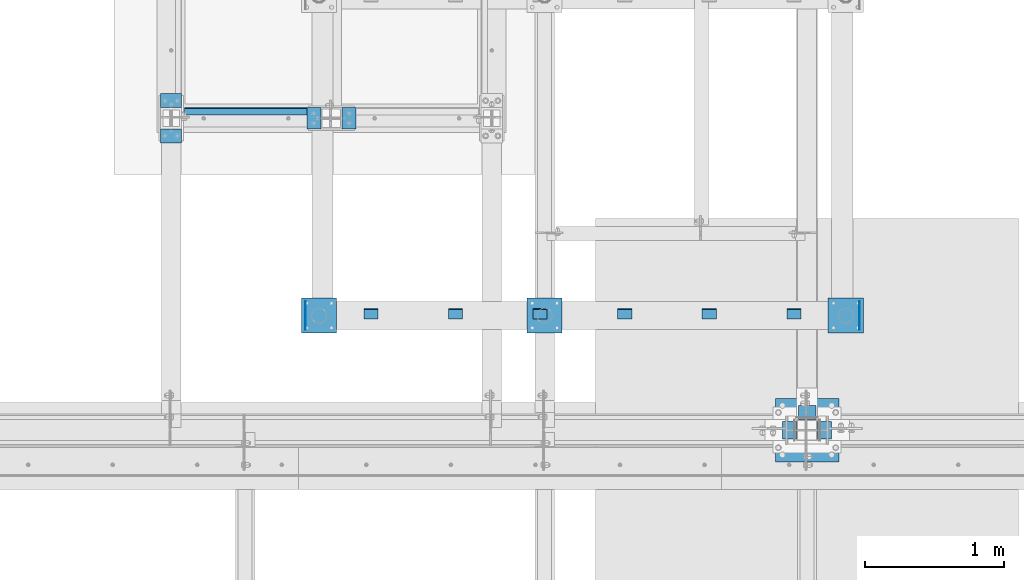
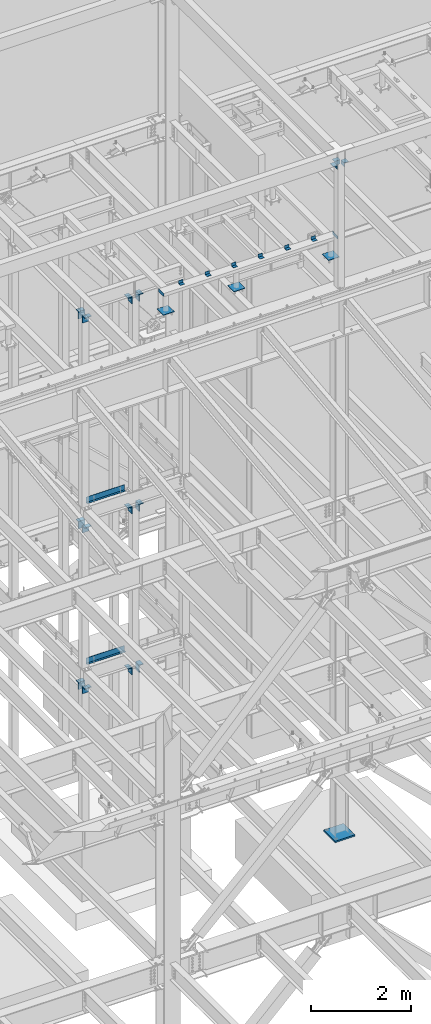
# One storey, part 891 of 1179: 29 beams, 11 elements without a shape of their own.
"""IFC2X3 building model written with IfcOpenShell, lengths in millimetres."""

from ifc_helpers import new_model, si_unit, frame, origin_with_axes, place, context, subcontext, project, spatial, faceted_brep, material, type_object, element, aggregate, save


model = new_model("IFC2X3")

# Units and contexts
model_context = context("Model", 3, precision=1e-05, world=origin_with_axes())
body_context = subcontext(model_context, "Body", "Model", "MODEL_VIEW")
ifc_project = project(units=[si_unit("LENGTHUNIT", "METRE", prefix="MILLI"), si_unit("AREAUNIT", "SQUARE_METRE"), si_unit("VOLUMEUNIT", "CUBIC_METRE"), si_unit("MASSUNIT", "GRAM", prefix="KILO"), si_unit("TIMEUNIT", "SECOND"), si_unit("PLANEANGLEUNIT", "RADIAN"), si_unit("SOLIDANGLEUNIT", "STERADIAN"), si_unit("THERMODYNAMICTEMPERATUREUNIT", "DEGREE_CELSIUS"), si_unit("LUMINOUSINTENSITYUNIT", "LUMEN")], contexts=[model_context])

# Site, building, storey
site_placement = place(None, origin_with_axes())
site = spatial("IfcSite", under=ifc_project, at=site_placement, CompositionType="ELEMENT")
building_placement = place(site_placement, origin_with_axes())
building = spatial("IfcBuilding", under=site, at=building_placement, Name="Undefined", CompositionType="ELEMENT")
storey_placement = place(building_placement, origin_with_axes())
storey = spatial("IfcBuildingStorey", under=building, at=storey_placement, Name="Undefined", CompositionType="ELEMENT", Elevation=0.0)

# Assembly, beams
assembly_1_placement = place(storey_placement, origin_with_axes())
assembly_1 = element("IfcElementAssembly", 1, at=assembly_1_placement, inside=storey, Name="FRAME", AssemblyPlace="NOTDEFINED", PredefinedType="RIGID_FRAME")
ifc_material_1 = material(Name="STEEL/A36")
beam_type_1 = type_object("IfcBeamType", Name="L3X3X1/4", PredefinedType="NOTDEFINED")
beam_1_placement = place(assembly_1_placement, frame((16313.15, 35229.8, 13798.55), z_axis=(0.0, 0.0, 1.0), x_axis=(1.0, 0.0, 0.0)))
beam_1 = element("IfcBeam", 2, at=beam_1_placement, type_object=beam_type_1, material=ifc_material_1, Name="ANGLE", ObjectType="L3X3X1/4", context=body_context, shape_type="Brep", body=[
    faceted_brep([(0.0, 38.0999999999985, -38.0999999999999), (0.0, 38.0999999999985, 38.0999999999999), (101.600000000035, 38.0999999999985, 38.099999999994), (101.599999999962, 38.0999999999985, -38.1000000000058), (0.0, 31.75, 38.1000000000004), (101.600000000035, 31.75, 38.099999999994), (0.0, 31.75, -31.75), (101.599999999969, 31.75, -31.7500000000064), (0.0, -38.0999999999985, -31.75), (101.599999999969, -38.0999999999985, -31.7500000000064), (0.0, -38.0999999999985, -38.0999999999999), (101.599999999962, -38.0999999999985, -38.1000000000058)], [[[0, 1, 2, 3]], [[1, 4, 5, 2]], [[4, 6, 7, 5]], [[6, 8, 9, 7]], [[8, 10, 11, 9]], [[10, 0, 3, 11]], [[5, 7, 9, 11, 3, 2]], [[10, 8, 6, 4, 1, 0]]]),
])
beam_2_placement = place(assembly_1_placement, frame((15703.55, 35229.8, 13798.55), z_axis=(0.0, 0.0, 1.0), x_axis=(1.0, 0.0, 0.0)))
beam_2 = element("IfcBeam", 3, at=beam_2_placement, type_object=beam_type_1, material=ifc_material_1, Name="ANGLE", ObjectType="L3X3X1/4", context=body_context, shape_type="Brep", body=[
    faceted_brep([(0.0, 38.0999999999985, -38.0999999999999), (0.0, 38.0999999999985, 38.0999999999999), (101.600000000035, 38.0999999999985, 38.099999999994), (101.599999999962, 38.0999999999985, -38.1000000000058), (0.0, 31.75, 38.1000000000004), (101.600000000035, 31.75, 38.099999999994), (0.0, 31.75, -31.75), (101.599999999969, 31.75, -31.7500000000064), (0.0, -38.0999999999985, -31.75), (101.599999999969, -38.0999999999985, -31.7500000000064), (0.0, -38.0999999999985, -38.0999999999999), (101.599999999962, -38.0999999999985, -38.1000000000058)], [[[0, 1, 2, 3]], [[1, 4, 5, 2]], [[4, 6, 7, 5]], [[6, 8, 9, 7]], [[8, 10, 11, 9]], [[10, 0, 3, 11]], [[5, 7, 9, 11, 3, 2]], [[10, 8, 6, 4, 1, 0]]]),
])
beam_3_placement = place(assembly_1_placement, frame((15093.95, 35229.8, 13798.55), z_axis=(0.0, 0.0, 1.0), x_axis=(1.0, 0.0, 0.0)))
beam_3 = element("IfcBeam", 4, at=beam_3_placement, type_object=beam_type_1, material=ifc_material_1, Name="ANGLE", ObjectType="L3X3X1/4", context=body_context, shape_type="Brep", body=[
    faceted_brep([(0.0, 38.0999999999985, -38.0999999999999), (0.0, 38.0999999999985, 38.0999999999999), (101.600000000035, 38.0999999999985, 38.099999999994), (101.599999999962, 38.0999999999985, -38.1000000000058), (0.0, 31.75, 38.1000000000004), (101.600000000035, 31.75, 38.099999999994), (0.0, 31.75, -31.75), (101.599999999969, 31.75, -31.7500000000064), (0.0, -38.0999999999985, -31.75), (101.599999999969, -38.0999999999985, -31.7500000000064), (0.0, -38.0999999999985, -38.0999999999999), (101.599999999962, -38.0999999999985, -38.1000000000058)], [[[0, 1, 2, 3]], [[1, 4, 5, 2]], [[4, 6, 7, 5]], [[6, 8, 9, 7]], [[8, 10, 11, 9]], [[10, 0, 3, 11]], [[5, 7, 9, 11, 3, 2]], [[10, 8, 6, 4, 1, 0]]]),
])
beam_4_placement = place(assembly_1_placement, frame((14484.35, 35229.8, 13798.55), z_axis=(0.0, 0.0, 1.0), x_axis=(1.0, 0.0, 0.0)))
beam_4 = element("IfcBeam", 5, at=beam_4_placement, type_object=beam_type_1, material=ifc_material_1, Name="ANGLE", ObjectType="L3X3X1/4", context=body_context, shape_type="Brep", body=[
    faceted_brep([(0.0, 38.0999999999985, -38.0999999999999), (0.0, 38.0999999999985, 38.0999999999999), (101.600000000035, 38.0999999999985, 38.099999999994), (101.599999999962, 38.0999999999985, -38.1000000000058), (0.0, 31.75, 38.1000000000004), (101.600000000035, 31.75, 38.099999999994), (0.0, 31.75, -31.75), (101.599999999969, 31.75, -31.7500000000064), (0.0, -38.0999999999985, -31.75), (101.599999999969, -38.0999999999985, -31.7500000000064), (0.0, -38.0999999999985, -38.0999999999999), (101.599999999962, -38.0999999999985, -38.1000000000058)], [[[0, 1, 2, 3]], [[1, 4, 5, 2]], [[4, 6, 7, 5]], [[6, 8, 9, 7]], [[8, 10, 11, 9]], [[10, 0, 3, 11]], [[5, 7, 9, 11, 3, 2]], [[10, 8, 6, 4, 1, 0]]]),
])
beam_5_placement = place(assembly_1_placement, frame((13874.75, 35229.8, 13798.55), z_axis=(0.0, 0.0, 1.0), x_axis=(1.0, 0.0, 0.0)))
beam_5 = element("IfcBeam", 6, at=beam_5_placement, type_object=beam_type_1, material=ifc_material_1, Name="ANGLE", ObjectType="L3X3X1/4", context=body_context, shape_type="Brep", body=[
    faceted_brep([(0.0, 38.0999999999985, -38.0999999999999), (0.0, 38.0999999999985, 38.0999999999999), (101.600000000035, 38.0999999999985, 38.099999999994), (101.599999999962, 38.0999999999985, -38.1000000000058), (0.0, 31.75, 38.1000000000004), (101.600000000035, 31.75, 38.099999999994), (0.0, 31.75, -31.75), (101.599999999969, 31.75, -31.7500000000064), (0.0, -38.0999999999985, -31.75), (101.599999999969, -38.0999999999985, -31.7500000000064), (0.0, -38.0999999999985, -38.0999999999999), (101.599999999962, -38.0999999999985, -38.1000000000058)], [[[0, 1, 2, 3]], [[1, 4, 5, 2]], [[4, 6, 7, 5]], [[6, 8, 9, 7]], [[8, 10, 11, 9]], [[10, 0, 3, 11]], [[5, 7, 9, 11, 3, 2]], [[10, 8, 6, 4, 1, 0]]]),
])
beam_6_placement = place(assembly_1_placement, frame((13265.15, 35229.8, 13798.55), z_axis=(0.0, 0.0, 1.0), x_axis=(1.0, 0.0, 0.0)))
beam_6 = element("IfcBeam", 7, at=beam_6_placement, type_object=beam_type_1, material=ifc_material_1, Name="ANGLE", ObjectType="L3X3X1/4", context=body_context, shape_type="Brep", body=[
    faceted_brep([(0.0, 38.0999999999985, -38.0999999999999), (0.0, 38.0999999999985, 38.0999999999999), (101.600000000035, 38.0999999999985, 38.099999999994), (101.599999999962, 38.0999999999985, -38.1000000000058), (0.0, 31.75, 38.1000000000004), (101.600000000035, 31.75, 38.099999999994), (0.0, 31.75, -31.75), (101.599999999969, 31.75, -31.7500000000064), (0.0, -38.0999999999985, -31.75), (101.599999999969, -38.0999999999985, -31.7500000000064), (0.0, -38.0999999999985, -38.0999999999999), (101.599999999962, -38.0999999999985, -38.1000000000058)], [[[0, 1, 2, 3]], [[1, 4, 5, 2]], [[4, 6, 7, 5]], [[6, 8, 9, 7]], [[8, 10, 11, 9]], [[10, 0, 3, 11]], [[5, 7, 9, 11, 3, 2]], [[10, 8, 6, 4, 1, 0]]]),
])
beam_type_2 = type_object("IfcBeamType", PredefinedType="NOTDEFINED")
beam_7_placement = place(assembly_1_placement, frame((16837.819, 35318.7, 13722.35), z_axis=(0.0, 0.0, 1.0), x_axis=(0.0, -1.0, 0.0)))
beam_7 = element("IfcBeam", 8, at=beam_7_placement, type_object=beam_type_2, material=ifc_material_1, Name="PLATE", context=body_context, shape_type="Brep", body=[
    faceted_brep([(0.0, 2.38149999999951, -38.0999999999985), (0.0, 2.38149999999951, 38.0999999999985), (203.199999999997, 2.38150000000314, 38.1000000000004), (203.199999999997, 2.38150000000314, -38.1000000000004), (0.0, -2.38149999999951, 38.0999999999985), (203.199999999997, -2.38150000000314, 38.1000000000004), (0.0, -2.38149999999951, -38.0999999999985), (203.199999999997, -2.38150000000314, -38.1000000000004)], [[[0, 1, 2, 3]], [[1, 4, 5, 2]], [[4, 6, 7, 5]], [[6, 0, 3, 7]], [[5, 7, 3, 2]], [[6, 4, 1, 0]]]),
])
beam_8_placement = place(assembly_1_placement, frame((12842.081, 35318.7, 13722.35), z_axis=(0.0, 0.0, -1.0), x_axis=(0.0, -1.0, 0.0)))
beam_8 = element("IfcBeam", 9, at=beam_8_placement, type_object=beam_type_2, material=ifc_material_1, Name="PLATE", context=body_context, shape_type="Brep", body=[
    faceted_brep([(0.0, 2.38149999999951, -38.0999999999985), (0.0, 2.38149999999951, 38.0999999999985), (203.199999999997, 2.38150000000314, 38.1000000000004), (203.199999999997, 2.38150000000314, -38.1000000000004), (0.0, -2.38149999999951, 38.0999999999985), (203.199999999997, -2.38150000000314, 38.1000000000004), (0.0, -2.38149999999951, -38.0999999999985), (203.199999999997, -2.38150000000314, -38.1000000000004)], [[[0, 1, 2, 3]], [[1, 4, 5, 2]], [[4, 6, 7, 5]], [[6, 0, 3, 7]], [[5, 7, 3, 2]], [[6, 4, 1, 0]]]),
])

# Assembly, beam
assembly_2_placement = place(storey_placement, origin_with_axes())
assembly_2 = element("IfcElementAssembly", 10, at=assembly_2_placement, inside=storey, Name="BEAM", AssemblyPlace="NOTDEFINED", PredefinedType="RIGID_FRAME")
beam_type_3 = type_object("IfcBeamType", PredefinedType="NOTDEFINED")
beam_9_placement = place(assembly_2_placement, frame((12414.24988175, 36712.5249960929, 8147.05000610352), z_axis=(1.0, 0.0, 0.0), x_axis=(0.0, 0.0, -1.0)))
beam_9 = element("IfcBeam", 11, at=beam_9_placement, type_object=beam_type_3, material=ifc_material_1, Name="BENT_PLATE", context=body_context, shape_type="Brep", body=[
    faceted_brep([(0.0, -3.17500000000291, -444.5), (0.0, -3.17500000000291, 444.5), (0.0, 3.17500000000291, 444.5), (0.0, 3.17500000000291, -444.5), (133.350006103513, 3.17500000000291, 444.5), (133.350006103513, 3.17500000000291, -444.5), (127.000006103513, -3.17500000000291, -444.5), (127.000006103513, -3.17500000000291, 444.5), (133.350006103513, -47.6249984741225, 444.5), (133.350006103513, -47.6249984741225, -444.5), (127.000006103513, -47.6249984741225, 444.5), (127.000006103513, -47.6249984741225, -444.5)], [[[0, 1, 2, 3]], [[3, 2, 4, 5]], [[1, 0, 6, 7]], [[5, 4, 8, 9]], [[4, 2, 1, 7, 10, 8]], [[7, 6, 11, 10]], [[6, 0, 3, 5, 9, 11]], [[10, 11, 9, 8]]]),
])
aggregate(assembly_2, [beam_9])

assembly_3_placement = place(storey_placement, origin_with_axes())
assembly_3 = element("IfcElementAssembly", 12, at=assembly_3_placement, inside=storey, Name="BEAM", AssemblyPlace="NOTDEFINED", PredefinedType="RIGID_FRAME")
beam_10_placement = place(assembly_3_placement, frame((12414.2500030518, 36712.5249984741, 4235.45000610352), z_axis=(1.0, 0.0, 0.0), x_axis=(0.0, 0.0, -1.0)))
beam_10 = element("IfcBeam", 13, at=beam_10_placement, type_object=beam_type_3, material=ifc_material_1, Name="BENT_PLATE", context=body_context, shape_type="Brep", body=[
    faceted_brep([(0.0, -3.17500000000291, -444.5), (0.0, -3.17500000000291, 444.5), (0.0, 3.17500000000291, 444.5), (0.0, 3.17500000000291, -444.5), (133.350006103513, 3.17500000000291, 444.5), (133.350006103513, 3.17500000000291, -444.5), (127.000006103513, -3.17500000000291, -444.5), (127.000006103513, -3.17500000000291, 444.5), (133.350006103513, -47.6249984741225, 444.5), (133.350006103513, -47.6249984741225, -444.5), (127.000006103513, -47.6249984741225, 444.5), (127.000006103513, -47.6249984741225, -444.5)], [[[0, 1, 2, 3]], [[3, 2, 4, 5]], [[1, 0, 6, 7]], [[5, 4, 8, 9]], [[4, 2, 1, 7, 10, 8]], [[7, 6, 11, 10]], [[6, 0, 3, 5, 9, 11]], [[10, 11, 9, 8]]]),
])
aggregate(assembly_3, [beam_10])

# Assembly, beams
assembly_4_placement = place(storey_placement, origin_with_axes())
assembly_4 = element("IfcElementAssembly", 14, at=assembly_4_placement, inside=storey, Name="COLUMN", AssemblyPlace="NOTDEFINED", PredefinedType="RIGID_FRAME")
beam_type_4 = type_object("IfcBeamType", Name="L4X4X3/8", PredefinedType="NOTDEFINED")
beam_11_placement = place(assembly_4_placement, frame((16522.7, 34518.6, 16071.85), z_axis=(0.0, 1.0, 0.0), x_axis=(-1.0, 0.0, 0.0)))
beam_11 = element("IfcBeam", 15, at=beam_11_placement, type_object=beam_type_4, material=ifc_material_1, Name="ANGLE", ObjectType="L4X4X3/8", context=body_context, shape_type="Brep", body=[
    faceted_brep([(1.90993887372315e-11, 50.8000000000002, -50.8000000000002), (1.90993887372315e-11, 50.8000000000002, 50.8000000000002), (126.999999999993, 50.8000000000002, 50.7999999999993), (126.999999999993, 50.8000000000002, -50.7999999999993), (0.0, 41.2750000000015, 50.8000000000029), (126.999999999993, 41.2749999999996, 50.7999999999993), (0.0, 41.2750000000015, -41.2750000000015), (126.999999999993, 41.2749999999996, -41.2749999999996), (0.0, -50.7999999999993, -41.2750000000015), (126.999999999993, -50.8000000000002, -41.2749999999996), (-1.81898940354586e-11, -50.7999999999997, -50.8000000000002), (126.999999999993, -50.8000000000002, -50.7999999999993)], [[[0, 1, 2, 3]], [[1, 4, 5, 2]], [[4, 6, 7, 5]], [[6, 8, 9, 7]], [[8, 10, 11, 9]], [[10, 0, 3, 11]], [[5, 7, 9, 11, 3, 2]], [[10, 8, 6, 4, 1, 0]]]),
])
beam_12_placement = place(assembly_4_placement, frame((16332.2, 34328.1, 16071.85), z_axis=(0.0, 0.0, -1.0), x_axis=(0.0, 1.0, 0.0)))
beam_12 = element("IfcBeam", 16, at=beam_12_placement, type_object=beam_type_4, material=ifc_material_1, Name="ANGLE", ObjectType="L4X4X3/8", context=body_context, shape_type="Brep", body=[
    faceted_brep([(1.90993887372315e-11, 50.8000000000002, -50.8000000000002), (1.90993887372315e-11, 50.8000000000002, 50.8000000000002), (126.999999999993, 50.8000000000002, 50.7999999999993), (126.999999999993, 50.8000000000002, -50.7999999999993), (0.0, 41.2750000000015, 50.8000000000029), (126.999999999993, 41.2749999999996, 50.7999999999993), (0.0, 41.2750000000015, -41.2750000000015), (126.999999999993, 41.2749999999996, -41.2749999999996), (0.0, -50.7999999999993, -41.2750000000015), (126.999999999993, -50.8000000000002, -41.2749999999996), (-1.81898940354586e-11, -50.7999999999997, -50.8000000000002), (126.999999999993, -50.8000000000002, -50.7999999999993)], [[[0, 1, 2, 3]], [[1, 4, 5, 2]], [[4, 6, 7, 5]], [[6, 8, 9, 7]], [[8, 10, 11, 9]], [[10, 0, 3, 11]], [[5, 7, 9, 11, 3, 2]], [[10, 8, 6, 4, 1, 0]]]),
])
beam_13_placement = place(assembly_4_placement, frame((16586.2, 34328.1, 16071.85), z_axis=(1.0, 0.0, 0.0), x_axis=(0.0, 1.0, 0.0)))
beam_13 = element("IfcBeam", 17, at=beam_13_placement, type_object=beam_type_4, material=ifc_material_1, Name="ANGLE", ObjectType="L4X4X3/8", context=body_context, shape_type="Brep", body=[
    faceted_brep([(1.90993887372315e-11, 50.8000000000002, -50.8000000000002), (1.90993887372315e-11, 50.8000000000002, 50.8000000000002), (126.999999999993, 50.8000000000002, 50.7999999999993), (126.999999999993, 50.8000000000002, -50.7999999999993), (0.0, 41.2750000000015, 50.8000000000029), (126.999999999993, 41.2749999999996, 50.7999999999993), (0.0, 41.2750000000015, -41.2750000000015), (126.999999999993, 41.2749999999996, -41.2749999999996), (0.0, -50.7999999999993, -41.2750000000015), (126.999999999993, -50.8000000000002, -41.2749999999996), (-1.81898940354586e-11, -50.7999999999997, -50.8000000000002), (126.999999999993, -50.8000000000002, -50.7999999999993)], [[[0, 1, 2, 3]], [[1, 4, 5, 2]], [[4, 6, 7, 5]], [[6, 8, 9, 7]], [[8, 10, 11, 9]], [[10, 0, 3, 11]], [[5, 7, 9, 11, 3, 2]], [[10, 8, 6, 4, 1, 0]]]),
])
aggregate(assembly_4, [beam_11, beam_12, beam_13])

assembly_5_placement = place(storey_placement, origin_with_axes())
assembly_5 = element("IfcElementAssembly", 18, at=assembly_5_placement, inside=storey, Name="COLUMN", AssemblyPlace="NOTDEFINED", PredefinedType="RIGID_FRAME")
beam_type_5 = type_object("IfcBeamType", PredefinedType="NOTDEFINED")
beam_14_placement = place(assembly_5_placement, frame((12852.4000014685, 36639.5000000217, 12763.5), z_axis=(0.0, 1.0, 0.0), x_axis=(1.0, 0.0, 0.0)))
beam_14 = element("IfcBeam", 19, at=beam_14_placement, type_object=beam_type_5, material=ifc_material_1, Name="BENT_PLATE", context=body_context, shape_type="Brep", body=[
    faceted_brep([(7.27595761418343e-12, -6.35000000000036, -76.1999999999971), (0.0, -6.35000000000036, 76.2000000000044), (0.0, 6.35000000000036, 76.2000000000044), (-7.27595761418343e-12, 6.35000000000036, -76.1999999999971), (88.8999984741222, 6.34999999999991, 76.2000000000007), (88.8999984741222, 6.34999999999991, -76.2000000000007), (101.599998474123, -6.34999999999991, -76.2000000000007), (101.599998474123, -6.34999999999991, 76.2000000000007), (88.8999984741222, 171.450003051757, 76.2000000000007), (88.8999984741222, 171.450003051757, -76.2000000000007), (101.599998474123, 171.450003051757, 76.2000000000007), (101.599998474123, 171.450003051757, -76.2000000000007)], [[[0, 1, 2, 3]], [[3, 2, 4, 5]], [[1, 0, 6, 7]], [[5, 4, 8, 9]], [[4, 2, 1, 7, 10, 8]], [[7, 6, 11, 10]], [[6, 0, 3, 5, 9, 11]], [[10, 11, 9, 8]]]),
])
beam_15_placement = place(assembly_5_placement, frame((13207.9999984167, 36639.500000021, 12763.5), z_axis=(0.0, 1.0, 0.0), x_axis=(-1.0, 0.0, 0.0)))
beam_15 = element("IfcBeam", 20, at=beam_15_placement, type_object=beam_type_5, material=ifc_material_1, Name="BENT_PLATE", context=body_context, shape_type="Brep", body=[
    faceted_brep([(7.27595761418343e-12, -6.35000000000036, -76.1999999999971), (0.0, -6.35000000000036, 76.2000000000044), (0.0, 6.35000000000036, 76.2000000000044), (-7.27595761418343e-12, 6.35000000000036, -76.1999999999971), (101.599998474123, 6.34999999999991, 76.2000000000007), (101.599998474123, 6.34999999999991, -76.2000000000007), (88.8999984741222, -6.34999999999991, -76.2000000000007), (88.8999984741222, -6.34999999999991, 76.2000000000007), (101.599998474123, -171.450003051757, 76.2000000000007), (101.599998474123, -171.450003051757, -76.2000000000007), (88.8999984741222, -171.450003051757, 76.2000000000007), (88.8999984741222, -171.450003051757, -76.2000000000007)], [[[0, 1, 2, 3]], [[3, 2, 4, 5]], [[1, 0, 6, 7]], [[5, 4, 8, 9]], [[4, 2, 1, 7, 10, 8]], [[7, 6, 11, 10]], [[6, 0, 3, 5, 9, 11]], [[10, 11, 9, 8]]]),
])
aggregate(assembly_5, [beam_14, beam_15])

assembly_6_placement = place(storey_placement, origin_with_axes())
assembly_6 = element("IfcElementAssembly", 21, at=assembly_6_placement, inside=storey, Name="COLUMN", AssemblyPlace="NOTDEFINED", PredefinedType="RIGID_FRAME")
beam_16_placement = place(assembly_6_placement, frame((11874.5, 36817.2999984741, 12709.525), z_axis=(1.0, 0.0, 0.0), x_axis=(0.0, -1.0, 0.0)))
beam_16 = element("IfcBeam", 22, at=beam_16_placement, type_object=beam_type_5, material=ifc_material_1, Name="BENT_PLATE", context=body_context, shape_type="Brep", body=[
    faceted_brep([(7.27595761418343e-12, -6.35000000000036, -76.1999999999971), (0.0, -6.35000000000036, 76.2000000000044), (0.0, 6.35000000000036, 76.2000000000044), (-7.27595761418343e-12, 6.35000000000036, -76.1999999999971), (88.8999984741222, 6.34999999999991, 76.2000000000007), (88.8999984741222, 6.34999999999991, -76.2000000000007), (101.599998474123, -6.34999999999991, -76.2000000000007), (101.599998474123, -6.34999999999991, 76.2000000000007), (88.8999984741222, 171.450003051757, 76.2000000000007), (88.8999984741222, 171.450003051757, -76.2000000000007), (101.599998474123, 171.450003051757, 76.2000000000007), (101.599998474123, 171.450003051757, -76.2000000000007)], [[[0, 1, 2, 3]], [[3, 2, 4, 5]], [[1, 0, 6, 7]], [[5, 4, 8, 9]], [[4, 2, 1, 7, 10, 8]], [[7, 6, 11, 10]], [[6, 0, 3, 5, 9, 11]], [[10, 11, 9, 8]]]),
])
beam_17_placement = place(assembly_6_placement, frame((11874.4999991706, 36461.7000015259, 12709.525), z_axis=(1.0, 0.0, 0.0), x_axis=(0.0, 1.0, 0.0)))
beam_17 = element("IfcBeam", 23, at=beam_17_placement, type_object=beam_type_5, material=ifc_material_1, Name="BENT_PLATE", context=body_context, shape_type="Brep", body=[
    faceted_brep([(7.27595761418343e-12, -6.35000000000036, -76.1999999999971), (0.0, -6.35000000000036, 76.2000000000044), (0.0, 6.35000000000036, 76.2000000000044), (-7.27595761418343e-12, 6.35000000000036, -76.1999999999971), (101.599998474123, 6.34999999999991, 76.2000000000007), (101.599998474123, 6.34999999999991, -76.2000000000007), (88.8999984741222, -6.34999999999991, -76.2000000000007), (88.8999984741222, -6.34999999999991, 76.2000000000007), (101.599998474123, -171.450003051757, 76.2000000000007), (101.599998474123, -171.450003051757, -76.2000000000007), (88.8999984741222, -171.450003051757, 76.2000000000007), (88.8999984741222, -171.450003051757, -76.2000000000007)], [[[0, 1, 2, 3]], [[3, 2, 4, 5]], [[1, 0, 6, 7]], [[5, 4, 8, 9]], [[4, 2, 1, 7, 10, 8]], [[7, 6, 11, 10]], [[6, 0, 3, 5, 9, 11]], [[10, 11, 9, 8]]]),
])
aggregate(assembly_6, [beam_16, beam_17])

assembly_7_placement = place(storey_placement, origin_with_axes())
assembly_7 = element("IfcElementAssembly", 24, at=assembly_7_placement, inside=storey, Name="COLUMN", AssemblyPlace="NOTDEFINED", PredefinedType="RIGID_FRAME")
beam_18_placement = place(assembly_7_placement, frame((12852.4000015259, 36639.5, 7658.1), z_axis=(0.0, 1.0, 0.0), x_axis=(1.0, 0.0, 0.0)))
beam_18 = element("IfcBeam", 25, at=beam_18_placement, type_object=beam_type_5, material=ifc_material_1, Name="BENT_PLATE", context=body_context, shape_type="Brep", body=[
    faceted_brep([(7.27595761418343e-12, -6.35000000000036, -76.1999999999971), (0.0, -6.35000000000036, 76.2000000000044), (0.0, 6.35000000000036, 76.2000000000044), (-7.27595761418343e-12, 6.35000000000036, -76.1999999999971), (88.8999984741222, 6.34999999999991, 76.2000000000007), (88.8999984741222, 6.34999999999991, -76.2000000000007), (101.599998474123, -6.34999999999991, -76.2000000000007), (101.599998474123, -6.34999999999991, 76.2000000000007), (88.8999984741222, 171.450003051757, 76.2000000000007), (88.8999984741222, 171.450003051757, -76.2000000000007), (101.599998474123, 171.450003051757, 76.2000000000007), (101.599998474123, 171.450003051757, -76.2000000000007)], [[[0, 1, 2, 3]], [[3, 2, 4, 5]], [[1, 0, 6, 7]], [[5, 4, 8, 9]], [[4, 2, 1, 7, 10, 8]], [[7, 6, 11, 10]], [[6, 0, 3, 5, 9, 11]], [[10, 11, 9, 8]]]),
])
beam_19_placement = place(assembly_7_placement, frame((13207.9999984741, 36639.5, 7658.1), z_axis=(0.0, 1.0, 0.0), x_axis=(-1.0, 0.0, 0.0)))
beam_19 = element("IfcBeam", 26, at=beam_19_placement, type_object=beam_type_5, material=ifc_material_1, Name="BENT_PLATE", context=body_context, shape_type="Brep", body=[
    faceted_brep([(7.27595761418343e-12, -6.35000000000036, -76.1999999999971), (0.0, -6.35000000000036, 76.2000000000044), (0.0, 6.35000000000036, 76.2000000000044), (-7.27595761418343e-12, 6.35000000000036, -76.1999999999971), (101.599998474123, 6.34999999999991, 76.2000000000007), (101.599998474123, 6.34999999999991, -76.2000000000007), (88.8999984741222, -6.34999999999991, -76.2000000000007), (88.8999984741222, -6.34999999999991, 76.2000000000007), (101.599998474123, -171.450003051757, 76.2000000000007), (101.599998474123, -171.450003051757, -76.2000000000007), (88.8999984741222, -171.450003051757, 76.2000000000007), (88.8999984741222, -171.450003051757, -76.2000000000007)], [[[0, 1, 2, 3]], [[3, 2, 4, 5]], [[1, 0, 6, 7]], [[5, 4, 8, 9]], [[4, 2, 1, 7, 10, 8]], [[7, 6, 11, 10]], [[6, 0, 3, 5, 9, 11]], [[10, 11, 9, 8]]]),
])
aggregate(assembly_7, [beam_18, beam_19])

assembly_8_placement = place(storey_placement, origin_with_axes())
assembly_8 = element("IfcElementAssembly", 27, at=assembly_8_placement, inside=storey, Name="COLUMN", AssemblyPlace="NOTDEFINED", PredefinedType="RIGID_FRAME")
beam_20_placement = place(assembly_8_placement, frame((11874.4999991706, 36817.3182468785, 7604.12499649481), z_axis=(1.0, 0.0, 0.0), x_axis=(0.0, -1.0, 0.0)))
beam_20 = element("IfcBeam", 28, at=beam_20_placement, type_object=beam_type_5, material=ifc_material_1, Name="BENT_PLATE", context=body_context, shape_type="Brep", body=[
    faceted_brep([(7.27595761418343e-12, -6.35000000000036, -76.1999999999971), (0.0, -6.35000000000036, 76.2000000000044), (0.0, 6.35000000000036, 76.2000000000044), (-7.27595761418343e-12, 6.35000000000036, -76.1999999999971), (88.8999984741222, 6.34999999999991, 76.2000000000007), (88.8999984741222, 6.34999999999991, -76.2000000000007), (101.599998474123, -6.34999999999991, -76.2000000000007), (101.599998474123, -6.34999999999991, 76.2000000000007), (88.8999984741222, 171.450003051757, 76.2000000000007), (88.8999984741222, 171.450003051757, -76.2000000000007), (101.599998474123, 171.450003051757, 76.2000000000007), (101.599998474123, 171.450003051757, -76.2000000000007)], [[[0, 1, 2, 3]], [[3, 2, 4, 5]], [[1, 0, 6, 7]], [[5, 4, 8, 9]], [[4, 2, 1, 7, 10, 8]], [[7, 6, 11, 10]], [[6, 0, 3, 5, 9, 11]], [[10, 11, 9, 8]]]),
])
beam_21_placement = place(assembly_8_placement, frame((11874.4999991706, 36461.7000015259, 7604.12499649481), z_axis=(1.0, 0.0, 0.0), x_axis=(0.0, 1.0, 0.0)))
beam_21 = element("IfcBeam", 29, at=beam_21_placement, type_object=beam_type_5, material=ifc_material_1, Name="BENT_PLATE", context=body_context, shape_type="Brep", body=[
    faceted_brep([(7.27595761418343e-12, -6.35000000000036, -76.1999999999971), (0.0, -6.35000000000036, 76.2000000000044), (0.0, 6.35000000000036, 76.2000000000044), (-7.27595761418343e-12, 6.35000000000036, -76.1999999999971), (101.599998474123, 6.34999999999991, 76.2000000000007), (101.599998474123, 6.34999999999991, -76.2000000000007), (88.8999984741222, -6.34999999999991, -76.2000000000007), (88.8999984741222, -6.34999999999991, 76.2000000000007), (101.599998474123, -171.450003051757, 76.2000000000007), (101.599998474123, -171.450003051757, -76.2000000000007), (88.8999984741222, -171.450003051757, 76.2000000000007), (88.8999984741222, -171.450003051757, -76.2000000000007)], [[[0, 1, 2, 3]], [[3, 2, 4, 5]], [[1, 0, 6, 7]], [[5, 4, 8, 9]], [[4, 2, 1, 7, 10, 8]], [[7, 6, 11, 10]], [[6, 0, 3, 5, 9, 11]], [[10, 11, 9, 8]]]),
])
aggregate(assembly_8, [beam_20, beam_21])

assembly_9_placement = place(storey_placement, origin_with_axes())
assembly_9 = element("IfcElementAssembly", 30, at=assembly_9_placement, inside=storey, Name="COLUMN", AssemblyPlace="NOTDEFINED", PredefinedType="RIGID_FRAME")
beam_22_placement = place(assembly_9_placement, frame((12852.4000015259, 36639.5, 3746.5), z_axis=(0.0, 1.0, 0.0), x_axis=(1.0, 0.0, 0.0)))
beam_22 = element("IfcBeam", 31, at=beam_22_placement, type_object=beam_type_5, material=ifc_material_1, Name="BENT_PLATE", context=body_context, shape_type="Brep", body=[
    faceted_brep([(7.27595761418343e-12, -6.35000000000036, -76.1999999999971), (0.0, -6.35000000000036, 76.2000000000044), (0.0, 6.35000000000036, 76.2000000000044), (-7.27595761418343e-12, 6.35000000000036, -76.1999999999971), (88.8999984741222, 6.34999999999991, 76.2000000000007), (88.8999984741222, 6.34999999999991, -76.2000000000007), (101.599998474123, -6.34999999999991, -76.2000000000007), (101.599998474123, -6.34999999999991, 76.2000000000007), (88.8999984741222, 171.450003051757, 76.2000000000007), (88.8999984741222, 171.450003051757, -76.2000000000007), (101.599998474123, 171.450003051757, 76.2000000000007), (101.599998474123, 171.450003051757, -76.2000000000007)], [[[0, 1, 2, 3]], [[3, 2, 4, 5]], [[1, 0, 6, 7]], [[5, 4, 8, 9]], [[4, 2, 1, 7, 10, 8]], [[7, 6, 11, 10]], [[6, 0, 3, 5, 9, 11]], [[10, 11, 9, 8]]]),
])
beam_23_placement = place(assembly_9_placement, frame((13207.9999984741, 36639.5, 3746.5), z_axis=(0.0, 1.0, 0.0), x_axis=(-1.0, 0.0, 0.0)))
beam_23 = element("IfcBeam", 32, at=beam_23_placement, type_object=beam_type_5, material=ifc_material_1, Name="BENT_PLATE", context=body_context, shape_type="Brep", body=[
    faceted_brep([(7.27595761418343e-12, -6.35000000000036, -76.1999999999971), (0.0, -6.35000000000036, 76.2000000000044), (0.0, 6.35000000000036, 76.2000000000044), (-7.27595761418343e-12, 6.35000000000036, -76.1999999999971), (101.599998474123, 6.34999999999991, 76.2000000000007), (101.599998474123, 6.34999999999991, -76.2000000000007), (88.8999984741222, -6.34999999999991, -76.2000000000007), (88.8999984741222, -6.34999999999991, 76.2000000000007), (101.599998474123, -171.450003051757, 76.2000000000007), (101.599998474123, -171.450003051757, -76.2000000000007), (88.8999984741222, -171.450003051757, 76.2000000000007), (88.8999984741222, -171.450003051757, -76.2000000000007)], [[[0, 1, 2, 3]], [[3, 2, 4, 5]], [[1, 0, 6, 7]], [[5, 4, 8, 9]], [[4, 2, 1, 7, 10, 8]], [[7, 6, 11, 10]], [[6, 0, 3, 5, 9, 11]], [[10, 11, 9, 8]]]),
])
aggregate(assembly_9, [beam_22, beam_23])

assembly_10_placement = place(storey_placement, origin_with_axes())
assembly_10 = element("IfcElementAssembly", 33, at=assembly_10_placement, inside=storey, Name="COLUMN", AssemblyPlace="NOTDEFINED", PredefinedType="RIGID_FRAME")
beam_24_placement = place(assembly_10_placement, frame((11874.4999993779, 36817.3181890931, 3692.52499649481), z_axis=(1.0, 0.0, 0.0), x_axis=(0.0, -1.0, 0.0)))
beam_24 = element("IfcBeam", 34, at=beam_24_placement, type_object=beam_type_5, material=ifc_material_1, Name="BENT_PLATE", context=body_context, shape_type="Brep", body=[
    faceted_brep([(7.27595761418343e-12, -6.35000000000036, -76.1999999999971), (0.0, -6.35000000000036, 76.2000000000044), (0.0, 6.35000000000036, 76.2000000000044), (-7.27595761418343e-12, 6.35000000000036, -76.1999999999971), (88.8999984741222, 6.34999999999991, 76.2000000000007), (88.8999984741222, 6.34999999999991, -76.2000000000007), (101.599998474123, -6.34999999999991, -76.2000000000007), (101.599998474123, -6.34999999999991, 76.2000000000007), (88.8999984741222, 171.450003051757, 76.2000000000007), (88.8999984741222, 171.450003051757, -76.2000000000007), (101.599998474123, 171.450003051757, 76.2000000000007), (101.599998474123, 171.450003051757, -76.2000000000007)], [[[0, 1, 2, 3]], [[3, 2, 4, 5]], [[1, 0, 6, 7]], [[5, 4, 8, 9]], [[4, 2, 1, 7, 10, 8]], [[7, 6, 11, 10]], [[6, 0, 3, 5, 9, 11]], [[10, 11, 9, 8]]]),
])
beam_25_placement = place(assembly_10_placement, frame((11874.5, 36461.7000015259, 3692.52499649481), z_axis=(1.0, 0.0, 0.0), x_axis=(0.0, 1.0, 0.0)))
beam_25 = element("IfcBeam", 35, at=beam_25_placement, type_object=beam_type_5, material=ifc_material_1, Name="BENT_PLATE", context=body_context, shape_type="Brep", body=[
    faceted_brep([(7.27595761418343e-12, -6.35000000000036, -76.1999999999971), (0.0, -6.35000000000036, 76.2000000000044), (0.0, 6.35000000000036, 76.2000000000044), (-7.27595761418343e-12, 6.35000000000036, -76.1999999999971), (101.599998474123, 6.34999999999991, 76.2000000000007), (101.599998474123, 6.34999999999991, -76.2000000000007), (88.8999984741222, -6.34999999999991, -76.2000000000007), (88.8999984741222, -6.34999999999991, 76.2000000000007), (101.599998474123, -171.450003051757, 76.2000000000007), (101.599998474123, -171.450003051757, -76.2000000000007), (88.8999984741222, -171.450003051757, 76.2000000000007), (88.8999984741222, -171.450003051757, -76.2000000000007)], [[[0, 1, 2, 3]], [[3, 2, 4, 5]], [[1, 0, 6, 7]], [[5, 4, 8, 9]], [[4, 2, 1, 7, 10, 8]], [[7, 6, 11, 10]], [[6, 0, 3, 5, 9, 11]], [[10, 11, 9, 8]]]),
])
aggregate(assembly_10, [beam_24, beam_25])

# Beam
beam_type_6 = type_object("IfcBeamType", PredefinedType="NOTDEFINED")
beam_26_placement = place(assembly_1_placement, frame((16738.6, 35090.1, 13258.8), z_axis=(1.0, 0.0, 0.0), x_axis=(0.0, 1.0, 0.0)))
beam_26 = element("IfcBeam", 36, at=beam_26_placement, type_object=beam_type_6, material=ifc_material_1, Name="PLATE", context=body_context, shape_type="Brep", body=[
    faceted_brep([(0.0, 6.35000000000036, -127.0), (0.0, 6.34999999999854, 127.0), (254.0, 6.35000000000036, 127.0), (254.0, 6.35000000000036, -127.0), (0.0, -6.34999999999854, 127.0), (254.0, -6.35000000000036, 127.0), (0.0, -6.35000000000036, -127.0), (254.0, -6.35000000000036, -127.0)], [[[0, 1, 2, 3]], [[1, 4, 5, 2]], [[4, 6, 7, 5]], [[6, 0, 3, 7]], [[5, 7, 3, 2]], [[6, 4, 1, 0]]]),
])

beam_27_placement = place(assembly_1_placement, frame((12941.3, 35090.1, 13258.8), z_axis=(1.0, 0.0, 0.0), x_axis=(0.0, 1.0, 0.0)))
beam_27 = element("IfcBeam", 37, at=beam_27_placement, type_object=beam_type_6, material=ifc_material_1, Name="PLATE", context=body_context, shape_type="Brep", body=[
    faceted_brep([(0.0, 6.35000000000036, -127.0), (0.0, 6.34999999999854, 127.0), (254.0, 6.35000000000036, 127.0), (254.0, 6.35000000000036, -127.0), (0.0, -6.34999999999854, 127.0), (254.0, -6.35000000000036, 127.0), (0.0, -6.35000000000036, -127.0), (254.0, -6.35000000000036, -127.0)], [[[0, 1, 2, 3]], [[1, 4, 5, 2]], [[4, 6, 7, 5]], [[6, 0, 3, 7]], [[5, 7, 3, 2]], [[6, 4, 1, 0]]]),
])

beam_28_placement = place(assembly_1_placement, frame((14566.9, 35090.1, 13258.8), z_axis=(1.0, 0.0, 0.0), x_axis=(0.0, 1.0, 0.0)))
beam_28 = element("IfcBeam", 38, at=beam_28_placement, type_object=beam_type_6, material=ifc_material_1, Name="PLATE", context=body_context, shape_type="Brep", body=[
    faceted_brep([(0.0, 6.35000000000036, -127.0), (0.0, 6.34999999999854, 127.0), (254.0, 6.35000000000036, 127.0), (254.0, 6.35000000000036, -127.0), (0.0, -6.34999999999854, 127.0), (254.0, -6.35000000000036, 127.0), (0.0, -6.35000000000036, -127.0), (254.0, -6.35000000000036, -127.0)], [[[0, 1, 2, 3]], [[1, 4, 5, 2]], [[4, 6, 7, 5]], [[6, 0, 3, 7]], [[5, 7, 3, 2]], [[6, 4, 1, 0]]]),
])

aggregate(assembly_1, [beam_1, beam_2, beam_3, beam_4, beam_5, beam_6, beam_7, beam_8, beam_26, beam_27, beam_28])

# Assembly, beam
assembly_11_placement = place(storey_placement, origin_with_axes())
assembly_11 = element("IfcElementAssembly", 39, at=assembly_11_placement, inside=storey, Name="COLUMN", AssemblyPlace="NOTDEFINED", PredefinedType="RIGID_FRAME")
ifc_material_2 = material(Name="STEEL/A572-GR.50")
beam_type_7 = type_object("IfcBeamType", PredefinedType="NOTDEFINED")
beam_29_placement = place(assembly_11_placement, frame((16459.2, 34163.0, -184.15), z_axis=(-1.0, 0.0, 0.0), x_axis=(0.0, 1.0, 0.0)))
beam_29 = element("IfcBeam", 40, at=beam_29_placement, type_object=beam_type_7, material=ifc_material_2, context=body_context, shape_type="Brep", body=[
    faceted_brep([(0.0, 19.05, -228.6), (0.0, 19.05, 228.6), (457.199999999997, 19.05, 228.599999999999), (457.199999999997, 19.05, -228.599999999999), (0.0, -19.05, 228.6), (457.199999999997, -19.05, 228.599999999999), (0.0, -19.05, -228.6), (457.199999999997, -19.05, -228.599999999999)], [[[0, 1, 2, 3]], [[1, 4, 5, 2]], [[4, 6, 7, 5]], [[6, 0, 3, 7]], [[5, 7, 3, 2]], [[6, 4, 1, 0]]]),
])
aggregate(assembly_11, [beam_29])

save(model, "model.ifc")
